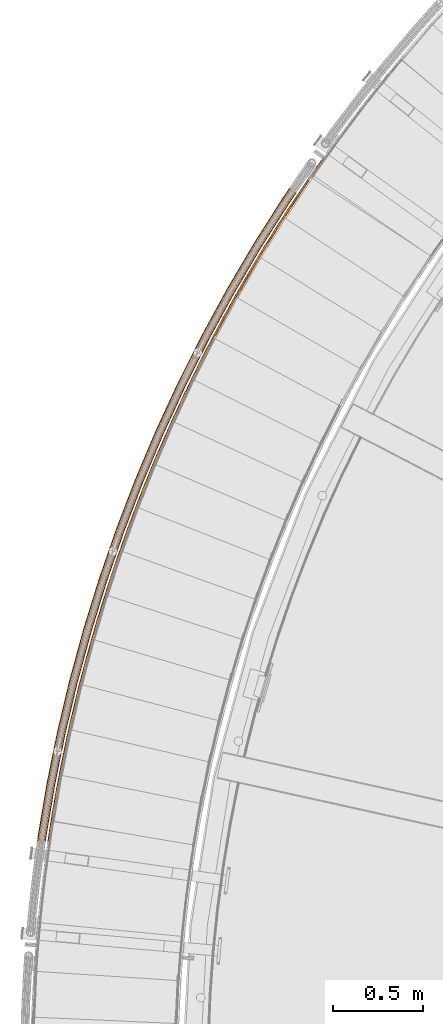
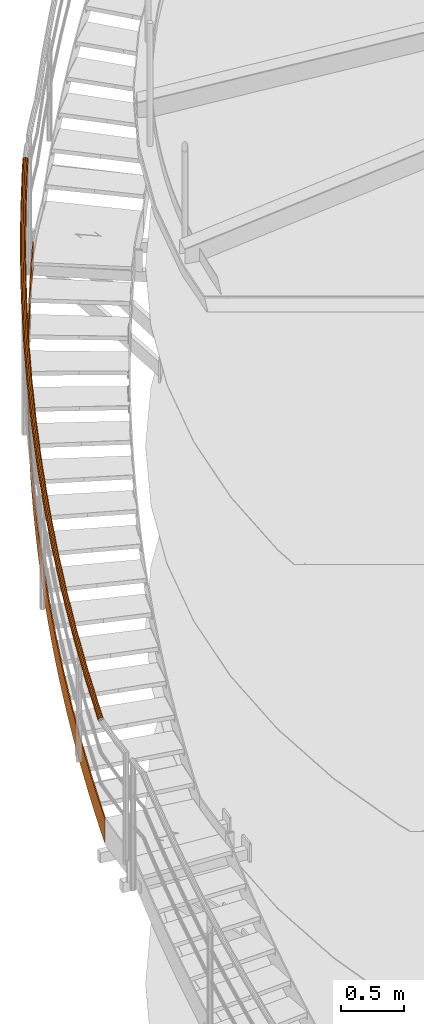
# One storey, part 26 of 126: 2 proxies.
"""IFC2X3 building model written with IfcOpenShell, lengths in millimetres."""

from ifc_helpers import new_model, si_unit, origin, origin_with_axes, place, context, project, spatial, faceted_brep, material, element, save


model = new_model("IFC2X3")

# Units and contexts
context_of_model_1 = context(None, 3, precision=0.1, world=origin())
context_of_model_2 = context(None, 3, precision=0.1, world=origin())
ifc_project = project(units=[si_unit("LENGTHUNIT", "METRE", prefix="MILLI"), si_unit("AREAUNIT", "SQUARE_METRE", prefix="CENTI"), si_unit("VOLUMEUNIT", "CUBIC_METRE", prefix="CENTI"), si_unit("MASSUNIT", "GRAM", prefix="KILO")], contexts=[context_of_model_1, context_of_model_2])

# Site, building, storey
site_placement = place(None, origin_with_axes())
site = spatial("IfcSite", under=ifc_project, at=site_placement, CompositionType="ELEMENT")
building_placement = place(site_placement, origin_with_axes())
building = spatial("IfcBuilding", under=site, at=building_placement, CompositionType="ELEMENT")
storey_placement = place(building_placement, origin_with_axes())
storey = spatial("IfcBuildingStorey", under=building, at=storey_placement, CompositionType="ELEMENT")

# Proxies
ifc_material = material(Name="S235JRG2")
proxy_1_placement = place(storey_placement, origin_with_axes())
element("IfcBuildingElementProxy", 1, at=proxy_1_placement, inside=storey, material=ifc_material, context=context_of_model_2, shape_type="Brep", body=[
    faceted_brep([(-726.5215, 9313.3481, 5409.2555), (-716.6318, 9311.8662, 5409.1818), (-718.1607, 9301.2803, 5402.0481), (-728.1705, 9301.9311, 5401.5657), (-716.6318, 9311.8662, 5649.5856), (-718.1607, 9301.2803, 5642.4497), (-726.5215, 9313.3481, 5649.6209), (-728.1705, 9301.9311, 5641.9335), (-712.1768, 9405.7396, 5471.5751), (-702.3033, 9404.1531, 5471.4807), (-702.3033, 9404.1531, 5711.8948), (-712.1768, 9405.7396, 5711.9301), (-696.8544, 9497.9741, 5533.89), (-686.9983, 9496.2831, 5533.7843), (-686.9983, 9496.2831, 5774.2041), (-696.8544, 9497.9741, 5774.2394), (-680.5562, 9590.0411, 5596.2023), (-670.7185, 9588.2458, 5596.0904), (-670.7185, 9588.2458, 5836.5133), (-680.5562, 9590.0411, 5836.5486), (-663.2839, 9681.9304, 5658.5132), (-653.4658, 9680.031, 5658.398), (-653.4658, 9680.031, 5898.8226), (-663.2839, 9681.9304, 5898.8579), (-645.0395, 9773.6316, 5720.8234), (-635.2421, 9771.6283, 5720.7064), (-635.2421, 9771.6283, 5961.1318), (-645.0395, 9773.6316, 5961.1671), (-625.8251, 9865.1344, 5783.1331), (-616.0494, 9863.0275, 5783.0151), (-616.0494, 9863.0275, 6023.4411), (-625.8251, 9865.1344, 6023.4764), (-605.6427, 9956.4287, 5845.4426), (-595.8899, 9954.2184, 5845.3241), (-595.8899, 9954.2184, 6085.7503), (-605.6427, 9956.4287, 6085.7856), (-584.4946, 10047.504, 5907.752), (-574.7658, 10045.191, 5907.6332), (-574.7658, 10045.191, 6148.0596), (-584.4946, 10047.504, 6148.0949), (-562.3833, 10138.35, 5970.0613), (-552.6795, 10135.934, 5969.9424), (-552.6795, 10135.934, 6210.3688), (-562.3833, 10138.35, 6210.4041), (-539.3112, 10228.958, 6032.3706), (-529.6335, 10226.439, 6032.2516), (-529.6335, 10226.439, 6272.6781), (-539.3112, 10228.958, 6272.7134), (-515.2809, 10319.315, 6094.6799), (-505.6304, 10316.694, 6094.5608), (-505.6304, 10316.694, 6334.9873), (-515.2809, 10319.315, 6335.0226), (-490.295, 10409.413, 6156.9892), (-480.6728, 10406.69, 6156.87), (-480.6728, 10406.69, 6397.2966), (-490.295, 10409.413, 6397.3319), (-464.3564, 10499.242, 6219.2984), (-454.7636, 10496.417, 6219.1793), (-454.7636, 10496.417, 6459.6058), (-464.3564, 10499.242, 6459.6411), (-437.468, 10588.791, 6281.6077), (-427.9057, 10585.864, 6281.4885), (-427.9057, 10585.864, 6521.915), (-437.468, 10588.791, 6521.9504), (-409.6328, 10678.05, 6343.9169), (-400.102, 10675.022, 6343.7978), (-400.102, 10675.022, 6584.2243), (-409.6328, 10678.05, 6584.2596), (-380.854, 10767.009, 6406.2262), (-371.3558, 10763.88, 6406.107), (-371.3558, 10763.88, 6646.5335), (-380.854, 10767.009, 6646.5688), (-351.1347, 10855.658, 6468.5354), (-341.6701, 10852.43, 6468.4163), (-341.6701, 10852.43, 6708.8428), (-351.1347, 10855.658, 6708.8781), (-320.4783, 10943.988, 6530.8447), (-311.0485, 10940.659, 6530.7255), (-311.0485, 10940.659, 6771.152), (-320.4783, 10943.988, 6771.1873), (-288.8882, 11031.988, 6593.1539), (-279.4942, 11028.56, 6593.0347), (-279.4942, 11028.56, 6833.4613), (-288.8882, 11031.988, 6833.4966), (-256.368, 11119.649, 6655.4631), (-247.0108, 11116.121, 6655.344), (-247.0108, 11116.121, 6895.7705), (-256.368, 11119.649, 6895.8058), (-222.9213, 11206.96, 6717.7724), (-213.602, 11203.334, 6717.6532), (-213.602, 11203.334, 6958.0798), (-222.9213, 11206.96, 6958.1151), (-188.5519, 11293.913, 6780.0816), (-179.2715, 11290.188, 6779.9625), (-179.2715, 11290.188, 7020.389), (-188.5519, 11293.913, 7020.4243), (-153.2635, 11380.496, 6842.3909), (-144.0231, 11376.673, 6842.2717), (-144.0231, 11376.673, 7082.6983), (-153.2635, 11380.496, 7082.7336), (-117.0603, 11466.701, 6904.7001), (-107.8609, 11462.781, 6904.581), (-107.8609, 11462.781, 7145.0075), (-117.0603, 11466.701, 7145.0428), (-79.9462, 11552.518, 6967.0094), (-70.7888, 11548.5, 6966.8902), (-70.7888, 11548.5, 7207.3168), (-79.9462, 11552.518, 7207.3521), (-41.9254, 11637.937, 7029.3186), (-32.8111, 11633.822, 7029.1995), (-32.8111, 11633.822, 7269.626), (-41.9254, 11637.937, 7269.6613), (-3.0022, 11722.949, 7091.6279), (6.068, 11718.737, 7091.5087), (6.068, 11718.737, 7331.9353), (-3.0022, 11722.949, 7331.9706), (36.8191, 11807.543, 7153.9371), (45.8442, 11803.236, 7153.818), (45.8442, 11803.236, 7394.2445), (36.8191, 11807.543, 7394.2798), (77.534, 11891.711, 7216.2464), (86.513, 11887.309, 7216.1272), (86.513, 11887.309, 7456.5538), (77.534, 11891.711, 7456.5891), (119.1379, 11975.443, 7278.5556), (128.0698, 11970.946, 7278.4365), (128.0698, 11970.946, 7518.863), (119.1379, 11975.443, 7518.8983), (161.6262, 12058.73, 7340.8649), (170.51, 12054.139, 7340.7457), (170.51, 12054.139, 7581.1723), (161.6262, 12058.73, 7581.2076), (204.9942, 12141.563, 7403.1741), (213.8288, 12136.877, 7403.055), (213.8288, 12136.877, 7643.4815), (204.9942, 12141.563, 7643.5168), (249.2368, 12223.931, 7465.4834), (258.0214, 12219.152, 7465.3642), (258.0214, 12219.152, 7705.7908), (249.2368, 12223.931, 7705.8261), (294.3493, 12305.826, 7527.7926), (303.0827, 12300.955, 7527.6735), (303.0827, 12300.955, 7768.1), (294.3493, 12305.826, 7768.1353), (340.3264, 12387.239, 7590.1019), (349.0078, 12382.276, 7589.9827), (349.0078, 12382.276, 7830.4092), (340.3264, 12387.239, 7830.4446), (387.1632, 12468.161, 7652.4111), (395.7915, 12463.106, 7652.292), (395.7915, 12463.106, 7892.7185), (387.1632, 12468.161, 7892.7538), (434.8542, 12548.582, 7714.7204), (443.4285, 12543.435, 7714.6012), (443.4285, 12543.435, 7955.0277), (434.8542, 12548.582, 7955.063), (483.3942, 12628.493, 7777.0296), (491.9136, 12623.256, 7776.9105), (491.9136, 12623.256, 8017.337), (483.3942, 12628.493, 8017.3723), (532.7778, 12707.886, 7839.3389), (541.2412, 12702.559, 7839.2197), (541.2412, 12702.559, 8079.6462), (532.7778, 12707.886, 8079.6815), (582.9993, 12786.752, 7901.6481), (591.4058, 12781.335, 7901.5289), (591.4058, 12781.335, 8141.9555), (582.9993, 12786.752, 8141.9908), (634.0532, 12865.081, 7963.9573), (642.4018, 12859.576, 7963.8382), (642.4018, 12859.576, 8204.2647), (634.0532, 12865.081, 8204.3), (685.9337, 12942.865, 8026.2666), (694.2236, 12937.272, 8026.1474), (694.2236, 12937.272, 8266.574), (685.9337, 12942.865, 8266.6093), (738.635, 13020.095, 8088.5758), (746.8652, 13014.415, 8088.4567), (746.8652, 13014.415, 8328.8832), (738.635, 13020.095, 8328.9185), (792.1512, 13096.763, 8150.8851), (800.3208, 13090.996, 8150.7659), (800.3208, 13090.996, 8391.1925), (792.1512, 13096.763, 8391.2278), (811.9618, 13124.513, 8173.6072), (820.2017, 13118.845, 8173.5947), (820.2017, 13118.845, 8414.0212), (811.9618, 13124.513, 8413.9499)], [[[0, 1, 2, 3]], [[1, 4, 5, 2]], [[4, 6, 7, 5]], [[0, 3, 7, 6]], [[0, 8, 9, 1]], [[1, 9, 10, 4]], [[4, 10, 11, 6]], [[6, 11, 8, 0]], [[8, 12, 13, 9]], [[9, 13, 14, 10]], [[10, 14, 15, 11]], [[11, 15, 12, 8]], [[12, 16, 17, 13]], [[13, 17, 18, 14]], [[14, 18, 19, 15]], [[15, 19, 16, 12]], [[16, 20, 21, 17]], [[17, 21, 22, 18]], [[18, 22, 23, 19]], [[19, 23, 20, 16]], [[20, 24, 25, 21]], [[21, 25, 26, 22]], [[22, 26, 27, 23]], [[23, 27, 24, 20]], [[24, 28, 29, 25]], [[25, 29, 30, 26]], [[26, 30, 31, 27]], [[27, 31, 28, 24]], [[28, 32, 33, 29]], [[29, 33, 34, 30]], [[30, 34, 35, 31]], [[31, 35, 32, 28]], [[32, 36, 37, 33]], [[33, 37, 38, 34]], [[34, 38, 39, 35]], [[35, 39, 36, 32]], [[36, 40, 41, 37]], [[37, 41, 42, 38]], [[38, 42, 43, 39]], [[39, 43, 40, 36]], [[40, 44, 45, 41]], [[41, 45, 46, 42]], [[42, 46, 47, 43]], [[43, 47, 44, 40]], [[44, 48, 49, 45]], [[45, 49, 50, 46]], [[46, 50, 51, 47]], [[47, 51, 48, 44]], [[48, 52, 53, 49]], [[49, 53, 54, 50]], [[50, 54, 55, 51]], [[51, 55, 52, 48]], [[52, 56, 57, 53]], [[53, 57, 58, 54]], [[54, 58, 59, 55]], [[55, 59, 56, 52]], [[56, 60, 61, 57]], [[57, 61, 62, 58]], [[58, 62, 63, 59]], [[59, 63, 60, 56]], [[60, 64, 65, 61]], [[61, 65, 66, 62]], [[62, 66, 67, 63]], [[63, 67, 64, 60]], [[64, 68, 69, 65]], [[65, 69, 70, 66]], [[66, 70, 71, 67]], [[67, 71, 68, 64]], [[68, 72, 73, 69]], [[69, 73, 74, 70]], [[70, 74, 75, 71]], [[71, 75, 72, 68]], [[72, 76, 77, 73]], [[73, 77, 78, 74]], [[74, 78, 79, 75]], [[75, 79, 76, 72]], [[76, 80, 81, 77]], [[77, 81, 82, 78]], [[78, 82, 83, 79]], [[79, 83, 80, 76]], [[80, 84, 85, 81]], [[81, 85, 86, 82]], [[82, 86, 87, 83]], [[83, 87, 84, 80]], [[84, 88, 89, 85]], [[85, 89, 90, 86]], [[86, 90, 91, 87]], [[87, 91, 88, 84]], [[88, 92, 93, 89]], [[89, 93, 94, 90]], [[90, 94, 95, 91]], [[91, 95, 92, 88]], [[92, 96, 97, 93]], [[93, 97, 98, 94]], [[94, 98, 99, 95]], [[95, 99, 96, 92]], [[96, 100, 101, 97]], [[97, 101, 102, 98]], [[98, 102, 103, 99]], [[99, 103, 100, 96]], [[100, 104, 105, 101]], [[101, 105, 106, 102]], [[102, 106, 107, 103]], [[103, 107, 104, 100]], [[104, 108, 109, 105]], [[105, 109, 110, 106]], [[106, 110, 111, 107]], [[107, 111, 108, 104]], [[108, 112, 113, 109]], [[109, 113, 114, 110]], [[110, 114, 115, 111]], [[111, 115, 112, 108]], [[112, 116, 117, 113]], [[113, 117, 118, 114]], [[114, 118, 119, 115]], [[115, 119, 116, 112]], [[116, 120, 121, 117]], [[117, 121, 122, 118]], [[118, 122, 123, 119]], [[119, 123, 120, 116]], [[120, 124, 125, 121]], [[121, 125, 126, 122]], [[122, 126, 127, 123]], [[123, 127, 124, 120]], [[124, 128, 129, 125]], [[125, 129, 130, 126]], [[126, 130, 131, 127]], [[127, 131, 128, 124]], [[128, 132, 133, 129]], [[129, 133, 134, 130]], [[130, 134, 135, 131]], [[131, 135, 132, 128]], [[132, 136, 137, 133]], [[133, 137, 138, 134]], [[134, 138, 139, 135]], [[135, 139, 136, 132]], [[136, 140, 141, 137]], [[137, 141, 142, 138]], [[138, 142, 143, 139]], [[139, 143, 140, 136]], [[140, 144, 145, 141]], [[141, 145, 146, 142]], [[142, 146, 147, 143]], [[143, 147, 144, 140]], [[144, 148, 149, 145]], [[145, 149, 150, 146]], [[146, 150, 151, 147]], [[147, 151, 148, 144]], [[148, 152, 153, 149]], [[149, 153, 154, 150]], [[150, 154, 155, 151]], [[151, 155, 152, 148]], [[152, 156, 157, 153]], [[153, 157, 158, 154]], [[154, 158, 159, 155]], [[155, 159, 156, 152]], [[156, 160, 161, 157]], [[157, 161, 162, 158]], [[158, 162, 163, 159]], [[159, 163, 160, 156]], [[160, 164, 165, 161]], [[161, 165, 166, 162]], [[162, 166, 167, 163]], [[163, 167, 164, 160]], [[164, 168, 169, 165]], [[165, 169, 170, 166]], [[166, 170, 171, 167]], [[167, 171, 168, 164]], [[168, 172, 173, 169]], [[169, 173, 174, 170]], [[170, 174, 175, 171]], [[171, 175, 172, 168]], [[172, 176, 177, 173]], [[173, 177, 178, 174]], [[174, 178, 179, 175]], [[175, 179, 176, 172]], [[176, 180, 181, 177]], [[177, 181, 182, 178]], [[178, 182, 183, 179]], [[179, 183, 180, 176]], [[180, 184, 185, 181]], [[181, 185, 186, 182]], [[182, 186, 187, 183]], [[180, 183, 187, 184]], [[2, 5, 7, 3]], [[184, 187, 186, 185]]]),
])
proxy_2_placement = place(storey_placement, origin_with_axes())
element("IfcBuildingElementProxy", 2, at=proxy_2_placement, inside=storey, material=ifc_material, Name="HANDLAUF", context=context_of_model_2, shape_type="Brep", body=[
    faceted_brep([(-761.4332, 9316.5433, 6657.9389), (-773.1405, 9320.1123, 6655.389), (-776.2437, 9296.7196, 6638.7572), (-764.3214, 9294.771, 6642.4592), (-781.2205, 9326.4212, 6648.2336), (-784.7017, 9300.1794, 6629.5762), (-783.5082, 9333.7795, 6638.3899), (-787.4291, 9304.2235, 6617.3762), (-779.3906, 9340.2156, 6628.4956), (-783.695, 9307.7683, 6605.4262), (-769.9709, 9344.005, 6621.2018), (-774.5, 9309.8639, 6596.9282), (-757.7732, 9344.1322, 6618.463), (-762.308, 9309.9488, 6594.1592), (-746.0659, 9340.5633, 6621.0128), (-750.3857, 9308.0003, 6597.8612), (-737.9859, 9334.2544, 6628.1683), (-741.9277, 9304.5405, 6607.0422), (-735.6982, 9326.8961, 6638.0119), (-739.2004, 9300.4964, 6619.2422), (-739.8158, 9320.4599, 6647.9062), (-742.9344, 9296.9516, 6631.1922), (-749.2355, 9316.6706, 6655.2), (-752.1294, 9294.856, 6639.6902), (-761.2437, 9317.9713, 6655.8956), (-750.3088, 9318.0854, 6653.4403), (-753.2873, 9295.6328, 6637.4769), (-764.2172, 9295.5566, 6639.9592), (-741.8642, 9321.4825, 6646.9015), (-745.0442, 9297.5115, 6629.8586), (-738.1728, 9327.2523, 6638.0315), (-741.6967, 9300.6893, 6619.1456), (-740.2237, 9333.8489, 6629.2068), (-744.1417, 9304.3147, 6608.2086), (-747.4673, 9339.5047, 6622.7922), (-751.7241, 9307.4164, 6599.978), (-757.9627, 9342.7042, 6620.5062), (-762.4122, 9309.1632, 6596.6592), (-768.8976, 9342.5902, 6622.9616), (-773.3421, 9309.0871, 6599.1415), (-777.3422, 9339.1931, 6629.5003), (-781.5852, 9307.2084, 6606.7598), (-781.0336, 9333.4232, 6638.3704), (-784.9328, 9304.0306, 6617.4727), (-778.9827, 9326.8266, 6647.195), (-782.4877, 9300.4051, 6628.4098), (-771.7391, 9321.1708, 6653.6097), (-774.9053, 9297.3034, 6636.6404), (-713.0048, 9607.1508, 6865.5856), (-724.5871, 9611.1069, 6863.0357), (-732.4528, 9617.6809, 6855.8801), (-734.4944, 9625.1112, 6846.0363), (-730.1651, 9631.4069, 6836.1421), (-720.6248, 9634.881, 6828.8485), (-708.4301, 9634.6028, 6826.1097), (-696.8482, 9630.6469, 6828.6595), (-688.9824, 9624.0731, 6835.8148), (-686.9404, 9616.6429, 6845.6583), (-691.2695, 9610.3471, 6855.5527), (-700.8097, 9606.8727, 6862.8467), (-712.768, 9608.5717, 6863.5424), (-701.8354, 9608.3224, 6861.0869), (-693.2827, 9611.4371, 6854.5481), (-689.4018, 9617.0812, 6845.678), (-691.2324, 9623.7422, 6836.8534), (-698.2839, 9629.6355, 6830.4388), (-708.6669, 9633.1819, 6828.153), (-719.5992, 9633.4313, 6830.6083), (-728.1519, 9630.3168, 6837.1468), (-732.033, 9624.6729, 6846.0168), (-730.2027, 9618.0118, 6854.8415), (-723.1513, 9612.1183, 6861.2564), (-654.9456, 9895.9884, 7073.2324), (-666.39, 9900.3272, 7070.6824), (-674.0329, 9907.159, 7063.5268), (-675.8265, 9914.653, 7053.6831), (-671.2903, 9920.8013, 7043.7888), (-661.6399, 9923.9565, 7036.4952), (-649.4611, 9923.2732, 7033.7565), (-638.0171, 9918.9346, 7036.3063), (-630.3741, 9912.103, 7043.4615), (-628.5801, 9904.609, 7053.3051), (-633.116, 9898.4605, 7063.1995), (-642.7664, 9895.3051, 7070.4934), (-654.6617, 9897.4006, 7071.1891), (-643.7434, 9896.7881, 7068.7337), (-635.0919, 9899.6169, 7062.1948), (-631.0256, 9905.1289, 7053.3247), (-632.6338, 9911.8471, 7044.5001), (-639.4856, 9917.9714, 7038.0856), (-649.745, 9921.8609, 7035.7997), (-660.663, 9922.4735, 7038.255), (-669.3144, 9919.6449, 7044.7936), (-673.381, 9914.1331, 7053.6636), (-671.7731, 9907.4148, 7062.4883), (-664.9214, 9901.2903, 7068.9031), (-587.3196, 10182.737, 7280.8791), (-598.6135, 10187.454, 7278.3291), (-606.0251, 10194.536, 7271.1736), (-607.5687, 10202.085, 7261.3298), (-602.8306, 10208.079, 7251.4356), (-593.0807, 10210.912, 7244.142), (-580.9314, 10209.824, 7241.4032), (-569.6379, 10205.108, 7243.953), (-562.2261, 10198.026, 7251.1083), (-560.6822, 10190.477, 7260.9518), (-565.4199, 10184.482, 7270.8462), (-575.1699, 10181.649, 7278.1402), (-586.989, 10184.139, 7278.8359), (-576.097, 10183.164, 7276.3804), (-567.3563, 10185.704, 7269.8416), (-563.1091, 10191.077, 7260.9715), (-564.4931, 10197.845, 7252.1469), (-571.1376, 10204.194, 7245.7323), (-581.262, 10208.422, 7243.4465), (-592.1537, 10209.397, 7245.9017), (-600.8943, 10206.858, 7252.4403), (-605.1418, 10201.484, 7261.3103), (-603.7581, 10194.716, 7270.135), (-597.1137, 10188.368, 7276.5499), (-510.2016, 10467.08, 7488.5259), (-521.3324, 10472.169, 7485.9759), (-528.5046, 10479.494, 7478.8203), (-529.7964, 10487.09, 7468.9765), (-524.8618, 10492.924, 7459.0823), (-515.0231, 10495.431, 7451.7887), (-502.9166, 10493.94, 7449.0499), (-491.7861, 10488.851, 7451.5998), (-484.6139, 10481.527, 7458.755), (-483.3217, 10473.93, 7468.5986), (-488.256, 10468.096, 7478.493), (-498.0947, 10465.589, 7485.7869), (-509.8245, 10468.47, 7486.4826), (-498.9709, 10467.134, 7484.0272), (-490.1507, 10469.381, 7477.4883), (-485.7272, 10474.611, 7468.6182), (-486.8856, 10481.421, 7459.7936), (-493.3154, 10487.987, 7453.3791), (-503.2937, 10492.55, 7451.0932), (-514.147, 10493.886, 7453.5485), (-522.9671, 10491.638, 7460.0871), (-527.3909, 10486.409, 7468.9571), (-526.2328, 10479.599, 7477.7818), (-519.8031, 10473.033, 7484.1966), (-423.6766, 10748.703, 7696.1726), (-434.6322, 10754.159, 7693.6226), (-441.557, 10761.718, 7686.467), (-442.5957, 10769.353, 7676.6233), (-437.4699, 10775.019, 7666.7291), (-427.5534, 10777.198, 7659.4355), (-415.5031, 10775.306, 7656.6967), (-404.5479, 10769.85, 7659.2465), (-397.623, 10762.291, 7666.4018), (-396.584, 10754.656, 7676.2453), (-401.7094, 10748.989, 7686.1397), (-411.626, 10746.81, 7693.4336), (-423.2536, 10750.08, 7694.1293), (-412.4504, 10748.383, 7691.6739), (-403.5604, 10750.337, 7685.1351), (-398.9655, 10755.416, 7676.265), (-399.897, 10762.261, 7667.4404), (-406.105, 10769.037, 7661.0258), (-415.9262, 10773.929, 7658.74), (-426.729, 10775.625, 7661.1952), (-435.619, 10773.672, 7667.7338), (-440.2141, 10768.593, 7676.6038), (-439.283, 10761.747, 7685.4285), (-433.075, 10754.971, 7691.8434), (-327.8404, 11027.295, 7903.8194), (-338.6086, 11033.112, 7901.2694), (-345.2784, 11040.897, 7894.1138), (-346.0627, 11048.563, 7884.27), (-340.7515, 11054.055, 7874.3758), (-330.768, 11055.903, 7867.0822), (-318.7873, 11053.612, 7864.3434), (-308.0195, 11047.794, 7866.8933), (-301.3496, 11040.01, 7874.0485), (-300.5649, 11032.344, 7883.8921), (-305.8758, 11026.851, 7893.7864), (-315.8593, 11025.003, 7901.0804), (-327.3719, 11028.657, 7901.7761), (-316.631, 11026.602, 7899.3207), (-307.681, 11028.259, 7892.7818), (-302.9199, 11033.183, 7883.9117), (-303.6233, 11040.056, 7875.0871), (-309.6027, 11047.034, 7868.6726), (-319.2559, 11052.249, 7866.3867), (-329.9964, 11054.304, 7868.842), (-338.9464, 11052.647, 7875.3806), (-343.7078, 11047.723, 7884.2505), (-343.0047, 11040.851, 7893.0753), (-337.0253, 11033.872, 7899.4901), (-222.7988, 11302.548, 8111.4661), (-233.3677, 11308.72, 8108.9161), (-239.7752, 11316.722, 8101.7605), (-240.3043, 11324.409, 8091.9168), (-234.8135, 11329.723, 8082.0226), (-224.7741, 11331.238, 8074.729), (-212.8761, 11328.549, 8071.9902), (-202.3075, 11322.377, 8074.54), (-195.9, 11314.375, 8081.6952), (-195.3705, 11306.688, 8091.5388), (-200.861, 11301.374, 8101.4332), (-210.9005, 11299.859, 8108.7271), (-222.2852, 11303.893, 8109.4228), (-211.6186, 11301.483, 8106.9674), (-202.6185, 11302.842, 8100.4286), (-197.6963, 11307.605, 8091.5584), (-198.171, 11314.497, 8082.7339), (-203.9152, 11321.67, 8076.3193), (-213.3897, 11327.203, 8074.0335), (-224.056, 11329.614, 8076.4887), (-233.0561, 11328.255, 8083.0273), (-237.9785, 11323.492, 8091.8973), (-237.5042, 11316.6, 8100.722), (-231.76, 11309.427, 8107.1368), (-108.6678, 11574.158, 8319.1129), (-119.0258, 11580.678, 8316.5629), (-125.1637, 11588.888, 8309.4073), (-125.4371, 11596.589, 8299.5635), (-119.7728, 11601.717, 8289.6693), (-109.6886, 11602.898, 8282.3757), (-97.8865, 11599.815, 8279.6369), (-87.5289, 11593.296, 8282.1867), (-81.3908, 11585.085, 8289.342), (-81.1171, 11577.384, 8299.1856), (-86.7812, 11572.256, 8309.0799), (-96.8654, 11571.075, 8316.3739), (-108.1098, 11575.486, 8317.0696), (-97.5292, 11572.722, 8314.6142), (-88.4889, 11573.781, 8308.0753), (-83.4111, 11578.378, 8299.2052), (-83.6565, 11585.282, 8290.3806), (-89.1591, 11592.642, 8283.9661), (-98.4446, 11598.487, 8281.6802), (-109.0249, 11601.251, 8284.1355), (-118.0652, 11600.192, 8290.6741), (-123.1431, 11595.595, 8299.544), (-122.898, 11588.692, 8308.3688), (-117.3955, 11581.331, 8314.7836), (14.4264, 11841.825, 8526.7596), (4.2909, 11848.686, 8524.2096), (-1.5708, 11857.096, 8517.054), (-1.5881, 11864.802, 8507.2103), (4.2435, 11869.738, 8497.3161), (14.3614, 11870.583, 8490.0225), (26.0544, 11867.11, 8487.2837), (36.1897, 11860.25, 8489.8335), (42.0515, 11851.84, 8496.9887), (42.0692, 11844.134, 8506.8323), (36.2378, 11839.197, 8516.7267), (26.1199, 11838.352, 8524.0206), (15.0283, 11843.134, 8524.7163), (25.5112, 11840.02, 8522.2609), (34.5817, 11840.778, 8515.7221), (39.8095, 11845.204, 8506.8519), (39.7936, 11852.112, 8498.0274), (34.5386, 11859.651, 8491.6128), (25.4526, 11865.802, 8489.3269), (14.97, 11868.915, 8491.7822), (5.8995, 11868.157, 8498.3208), (0.6716, 11863.732, 8507.1908), (0.6871, 11856.824, 8516.0155), (5.942, 11849.285, 8522.4303), (146.348, 12105.254, 8734.4063), (136.4461, 12112.448, 8731.8564), (130.8671, 12121.048, 8724.7008), (131.1059, 12128.75, 8714.857), (137.0983, 12133.49, 8704.9628), (147.2387, 12133.998, 8697.6692), (158.8099, 12130.139, 8694.9304), (168.7115, 12122.945, 8697.4802), (174.2906, 12114.345, 8704.6355), (174.0522, 12106.643, 8714.4791), (168.06, 12101.903, 8724.3734), (157.9195, 12101.394, 8731.6674), (146.993, 12106.542, 8732.3631), (157.3667, 12103.082, 8729.9077), (166.4574, 12103.538, 8723.3688), (171.8293, 12107.787, 8714.4987), (172.043, 12114.692, 8705.6741), (167.0415, 12122.402, 8699.2596), (158.1648, 12128.851, 8696.9737), (147.7915, 12132.311, 8699.429), (138.7009, 12131.855, 8705.9676), (133.3287, 12127.606, 8714.8375), (133.1147, 12120.701, 8723.6623), (138.1161, 12112.991, 8730.0771), (286.9511, 12364.153, 8942.0531), (277.2937, 12371.672, 8939.5031), (272.0036, 12380.453, 8932.3475), (272.4982, 12388.143, 8922.5038), (278.6449, 12392.681, 8912.6096), (288.7966, 12392.852, 8905.316), (300.2331, 12388.61, 8902.5772), (309.8902, 12381.091, 8905.127), (315.1805, 12372.311, 8912.2822), (314.6862, 12364.621, 8922.1258), (308.5398, 12360.082, 8932.0202), (298.388, 12359.911, 8939.3141), (287.6386, 12365.419, 8940.0098), (297.8915, 12361.616, 8937.5544), (306.9924, 12361.77, 8931.0155), (312.5025, 12365.838, 8922.1454), (312.9456, 12372.732, 8913.3209), (308.2031, 12380.604, 8906.9063), (299.5456, 12387.344, 8904.6204), (289.293, 12391.147, 8907.0757), (280.1922, 12390.994, 8913.6143), (274.6819, 12386.925, 8922.4843), (274.2385, 12380.031, 8931.309), (278.9809, 12372.16, 8937.7238), (436.0805, 12618.237, 9149.6998), (426.6783, 12626.072, 9147.1499), (421.6829, 12635.024, 9139.9943), (422.4328, 12642.693, 9130.1505), (428.727, 12647.025, 9120.2563), (438.8787, 12646.858, 9112.9627), (450.1679, 12642.238, 9110.2239), (459.5698, 12634.403, 9112.7737), (464.5653, 12625.452, 9119.929), (463.8158, 12617.782, 9129.7725), (457.5219, 12613.451, 9139.6669), (447.3701, 12613.617, 9146.9609), (436.8097, 12619.479, 9147.6566), (446.9305, 12615.337, 9145.2011), (456.0315, 12615.188, 9138.6623), (461.6738, 12619.072, 9129.7922), (462.3458, 12625.947, 9120.9676), (457.8674, 12633.972, 9114.553), (449.4387, 12640.996, 9112.2672), (439.3182, 12645.138, 9114.7225), (430.2173, 12645.287, 9121.261), (424.5748, 12641.404, 9130.131), (423.9025, 12634.529, 9138.9557), (428.3808, 12626.504, 9145.3706), (593.5714, 12867.224, 9357.3466), (584.4348, 12875.368, 9354.7966), (579.7396, 12884.481, 9347.641), (580.744, 12892.12, 9337.7973), (587.1786, 12896.241, 9327.9031), (597.3192, 12895.737, 9320.6095), (608.4486, 12890.744, 9317.8707), (617.585, 12882.601, 9320.4205), (622.2802, 12873.488, 9327.5757), (621.2763, 12865.848, 9337.4193), (614.8419, 12861.728, 9347.3137), (604.7012, 12862.231, 9354.6076), (594.3414, 12868.441, 9355.3033), (604.3191, 12863.966, 9352.8479), (613.41, 12863.514, 9346.309), (619.1783, 12867.208, 9337.4389), (620.0784, 12874.057, 9328.6144), (615.8692, 12882.226, 9322.1998), (607.6786, 12889.527, 9319.9139), (597.7012, 12894.003, 9322.3692), (588.6104, 12894.454, 9328.9078), (582.8419, 12890.761, 9337.7778), (581.9416, 12883.912, 9346.6025), (586.1506, 12875.742, 9353.0173), (638.7269, 12933.621, 9413.9405), (629.3682, 12941.41, 9411.0187), (623.5934, 12948.857, 9402.4114), (622.9469, 12953.97, 9390.4256), (627.6004, 12955.38, 9378.27), (636.3088, 12952.71, 9369.1984), (646.7417, 12946.673, 9365.6408), (656.1049, 12938.884, 9368.5533), (661.8879, 12931.432, 9377.159), (662.5382, 12926.314, 9389.1525), (657.8801, 12924.903, 9401.3173), (649.1634, 12927.579, 9410.3906), (639.1433, 12934.296, 9411.4405), (648.4993, 12928.879, 9408.2577), (656.3132, 12926.481, 9400.1238), (660.4889, 12927.745, 9389.2186), (659.9061, 12932.333, 9378.4671), (654.7221, 12939.014, 9370.7522), (646.3284, 12945.996, 9368.1407), (636.9754, 12951.408, 9371.3297), (629.1681, 12953.802, 9379.4623), (624.9961, 12952.538, 9390.36), (625.5759, 12947.955, 9401.1054), (630.7532, 12941.278, 9408.8216)], [[[0, 1, 2, 3]], [[1, 4, 5, 2]], [[4, 6, 7, 5]], [[6, 8, 9, 7]], [[8, 10, 11, 9]], [[10, 12, 13, 11]], [[12, 14, 15, 13]], [[14, 16, 17, 15]], [[16, 18, 19, 17]], [[18, 20, 21, 19]], [[20, 22, 23, 21]], [[0, 3, 23, 22]], [[24, 25, 26, 27]], [[25, 28, 29, 26]], [[28, 30, 31, 29]], [[30, 32, 33, 31]], [[32, 34, 35, 33]], [[34, 36, 37, 35]], [[36, 38, 39, 37]], [[38, 40, 41, 39]], [[40, 42, 43, 41]], [[42, 44, 45, 43]], [[44, 46, 47, 45]], [[24, 27, 47, 46]], [[0, 48, 49, 1]], [[1, 49, 50, 4]], [[4, 50, 51, 6]], [[6, 51, 52, 8]], [[8, 52, 53, 10]], [[10, 53, 54, 12]], [[12, 54, 55, 14]], [[14, 55, 56, 16]], [[16, 56, 57, 18]], [[18, 57, 58, 20]], [[20, 58, 59, 22]], [[22, 59, 48, 0]], [[24, 60, 61, 25]], [[25, 61, 62, 28]], [[28, 62, 63, 30]], [[30, 63, 64, 32]], [[32, 64, 65, 34]], [[34, 65, 66, 36]], [[36, 66, 67, 38]], [[38, 67, 68, 40]], [[40, 68, 69, 42]], [[42, 69, 70, 44]], [[44, 70, 71, 46]], [[46, 71, 60, 24]], [[48, 72, 73, 49]], [[49, 73, 74, 50]], [[50, 74, 75, 51]], [[51, 75, 76, 52]], [[52, 76, 77, 53]], [[53, 77, 78, 54]], [[54, 78, 79, 55]], [[55, 79, 80, 56]], [[56, 80, 81, 57]], [[57, 81, 82, 58]], [[58, 82, 83, 59]], [[59, 83, 72, 48]], [[60, 84, 85, 61]], [[61, 85, 86, 62]], [[62, 86, 87, 63]], [[63, 87, 88, 64]], [[64, 88, 89, 65]], [[65, 89, 90, 66]], [[66, 90, 91, 67]], [[67, 91, 92, 68]], [[68, 92, 93, 69]], [[69, 93, 94, 70]], [[70, 94, 95, 71]], [[71, 95, 84, 60]], [[72, 96, 97, 73]], [[73, 97, 98, 74]], [[74, 98, 99, 75]], [[75, 99, 100, 76]], [[76, 100, 101, 77]], [[77, 101, 102, 78]], [[78, 102, 103, 79]], [[79, 103, 104, 80]], [[80, 104, 105, 81]], [[81, 105, 106, 82]], [[82, 106, 107, 83]], [[83, 107, 96, 72]], [[84, 108, 109, 85]], [[85, 109, 110, 86]], [[86, 110, 111, 87]], [[87, 111, 112, 88]], [[88, 112, 113, 89]], [[89, 113, 114, 90]], [[90, 114, 115, 91]], [[91, 115, 116, 92]], [[92, 116, 117, 93]], [[93, 117, 118, 94]], [[94, 118, 119, 95]], [[95, 119, 108, 84]], [[96, 120, 121, 97]], [[97, 121, 122, 98]], [[98, 122, 123, 99]], [[99, 123, 124, 100]], [[100, 124, 125, 101]], [[101, 125, 126, 102]], [[102, 126, 127, 103]], [[103, 127, 128, 104]], [[104, 128, 129, 105]], [[105, 129, 130, 106]], [[106, 130, 131, 107]], [[107, 131, 120, 96]], [[108, 132, 133, 109]], [[109, 133, 134, 110]], [[110, 134, 135, 111]], [[111, 135, 136, 112]], [[112, 136, 137, 113]], [[113, 137, 138, 114]], [[114, 138, 139, 115]], [[115, 139, 140, 116]], [[116, 140, 141, 117]], [[117, 141, 142, 118]], [[118, 142, 143, 119]], [[119, 143, 132, 108]], [[120, 144, 145, 121]], [[121, 145, 146, 122]], [[122, 146, 147, 123]], [[123, 147, 148, 124]], [[124, 148, 149, 125]], [[125, 149, 150, 126]], [[126, 150, 151, 127]], [[127, 151, 152, 128]], [[128, 152, 153, 129]], [[129, 153, 154, 130]], [[130, 154, 155, 131]], [[131, 155, 144, 120]], [[132, 156, 157, 133]], [[133, 157, 158, 134]], [[134, 158, 159, 135]], [[135, 159, 160, 136]], [[136, 160, 161, 137]], [[137, 161, 162, 138]], [[138, 162, 163, 139]], [[139, 163, 164, 140]], [[140, 164, 165, 141]], [[141, 165, 166, 142]], [[142, 166, 167, 143]], [[143, 167, 156, 132]], [[144, 168, 169, 145]], [[145, 169, 170, 146]], [[146, 170, 171, 147]], [[147, 171, 172, 148]], [[148, 172, 173, 149]], [[149, 173, 174, 150]], [[150, 174, 175, 151]], [[151, 175, 176, 152]], [[152, 176, 177, 153]], [[153, 177, 178, 154]], [[154, 178, 179, 155]], [[155, 179, 168, 144]], [[156, 180, 181, 157]], [[157, 181, 182, 158]], [[158, 182, 183, 159]], [[159, 183, 184, 160]], [[160, 184, 185, 161]], [[161, 185, 186, 162]], [[162, 186, 187, 163]], [[163, 187, 188, 164]], [[164, 188, 189, 165]], [[165, 189, 190, 166]], [[166, 190, 191, 167]], [[167, 191, 180, 156]], [[168, 192, 193, 169]], [[169, 193, 194, 170]], [[170, 194, 195, 171]], [[171, 195, 196, 172]], [[172, 196, 197, 173]], [[173, 197, 198, 174]], [[174, 198, 199, 175]], [[175, 199, 200, 176]], [[176, 200, 201, 177]], [[177, 201, 202, 178]], [[178, 202, 203, 179]], [[179, 203, 192, 168]], [[180, 204, 205, 181]], [[181, 205, 206, 182]], [[182, 206, 207, 183]], [[183, 207, 208, 184]], [[184, 208, 209, 185]], [[185, 209, 210, 186]], [[186, 210, 211, 187]], [[187, 211, 212, 188]], [[188, 212, 213, 189]], [[189, 213, 214, 190]], [[190, 214, 215, 191]], [[191, 215, 204, 180]], [[192, 216, 217, 193]], [[193, 217, 218, 194]], [[194, 218, 219, 195]], [[195, 219, 220, 196]], [[196, 220, 221, 197]], [[197, 221, 222, 198]], [[198, 222, 223, 199]], [[199, 223, 224, 200]], [[200, 224, 225, 201]], [[201, 225, 226, 202]], [[202, 226, 227, 203]], [[203, 227, 216, 192]], [[204, 228, 229, 205]], [[205, 229, 230, 206]], [[206, 230, 231, 207]], [[207, 231, 232, 208]], [[208, 232, 233, 209]], [[209, 233, 234, 210]], [[210, 234, 235, 211]], [[211, 235, 236, 212]], [[212, 236, 237, 213]], [[213, 237, 238, 214]], [[214, 238, 239, 215]], [[215, 239, 228, 204]], [[216, 240, 241, 217]], [[217, 241, 242, 218]], [[218, 242, 243, 219]], [[219, 243, 244, 220]], [[220, 244, 245, 221]], [[221, 245, 246, 222]], [[222, 246, 247, 223]], [[223, 247, 248, 224]], [[224, 248, 249, 225]], [[225, 249, 250, 226]], [[226, 250, 251, 227]], [[227, 251, 240, 216]], [[228, 252, 253, 229]], [[229, 253, 254, 230]], [[230, 254, 255, 231]], [[231, 255, 256, 232]], [[232, 256, 257, 233]], [[233, 257, 258, 234]], [[234, 258, 259, 235]], [[235, 259, 260, 236]], [[236, 260, 261, 237]], [[237, 261, 262, 238]], [[238, 262, 263, 239]], [[239, 263, 252, 228]], [[240, 264, 265, 241]], [[241, 265, 266, 242]], [[242, 266, 267, 243]], [[243, 267, 268, 244]], [[244, 268, 269, 245]], [[245, 269, 270, 246]], [[246, 270, 271, 247]], [[247, 271, 272, 248]], [[248, 272, 273, 249]], [[249, 273, 274, 250]], [[250, 274, 275, 251]], [[251, 275, 264, 240]], [[252, 276, 277, 253]], [[253, 277, 278, 254]], [[254, 278, 279, 255]], [[255, 279, 280, 256]], [[256, 280, 281, 257]], [[257, 281, 282, 258]], [[258, 282, 283, 259]], [[259, 283, 284, 260]], [[260, 284, 285, 261]], [[261, 285, 286, 262]], [[262, 286, 287, 263]], [[263, 287, 276, 252]], [[264, 288, 289, 265]], [[265, 289, 290, 266]], [[266, 290, 291, 267]], [[267, 291, 292, 268]], [[268, 292, 293, 269]], [[269, 293, 294, 270]], [[270, 294, 295, 271]], [[271, 295, 296, 272]], [[272, 296, 297, 273]], [[273, 297, 298, 274]], [[274, 298, 299, 275]], [[275, 299, 288, 264]], [[276, 300, 301, 277]], [[277, 301, 302, 278]], [[278, 302, 303, 279]], [[279, 303, 304, 280]], [[280, 304, 305, 281]], [[281, 305, 306, 282]], [[282, 306, 307, 283]], [[283, 307, 308, 284]], [[284, 308, 309, 285]], [[285, 309, 310, 286]], [[286, 310, 311, 287]], [[287, 311, 300, 276]], [[288, 312, 313, 289]], [[289, 313, 314, 290]], [[290, 314, 315, 291]], [[291, 315, 316, 292]], [[292, 316, 317, 293]], [[293, 317, 318, 294]], [[294, 318, 319, 295]], [[295, 319, 320, 296]], [[296, 320, 321, 297]], [[297, 321, 322, 298]], [[298, 322, 323, 299]], [[299, 323, 312, 288]], [[300, 324, 325, 301]], [[301, 325, 326, 302]], [[302, 326, 327, 303]], [[303, 327, 328, 304]], [[304, 328, 329, 305]], [[305, 329, 330, 306]], [[306, 330, 331, 307]], [[307, 331, 332, 308]], [[308, 332, 333, 309]], [[309, 333, 334, 310]], [[310, 334, 335, 311]], [[311, 335, 324, 300]], [[312, 336, 337, 313]], [[313, 337, 338, 314]], [[314, 338, 339, 315]], [[315, 339, 340, 316]], [[316, 340, 341, 317]], [[317, 341, 342, 318]], [[318, 342, 343, 319]], [[319, 343, 344, 320]], [[320, 344, 345, 321]], [[321, 345, 346, 322]], [[322, 346, 347, 323]], [[323, 347, 336, 312]], [[324, 348, 349, 325]], [[325, 349, 350, 326]], [[326, 350, 351, 327]], [[327, 351, 352, 328]], [[328, 352, 353, 329]], [[329, 353, 354, 330]], [[330, 354, 355, 331]], [[331, 355, 356, 332]], [[332, 356, 357, 333]], [[333, 357, 358, 334]], [[334, 358, 359, 335]], [[335, 359, 348, 324]], [[336, 360, 361, 337]], [[337, 361, 362, 338]], [[338, 362, 363, 339]], [[339, 363, 364, 340]], [[340, 364, 365, 341]], [[341, 365, 366, 342]], [[342, 366, 367, 343]], [[343, 367, 368, 344]], [[344, 368, 369, 345]], [[345, 369, 370, 346]], [[346, 370, 371, 347]], [[336, 347, 371, 360]], [[348, 372, 373, 349]], [[349, 373, 374, 350]], [[350, 374, 375, 351]], [[351, 375, 376, 352]], [[352, 376, 377, 353]], [[353, 377, 378, 354]], [[354, 378, 379, 355]], [[355, 379, 380, 356]], [[356, 380, 381, 357]], [[357, 381, 382, 358]], [[358, 382, 383, 359]], [[348, 359, 383, 372]], [[7, 9, 11, 13, 15, 17, 19, 21, 23, 3, 2, 5], [26, 29, 31, 33, 35, 37, 39, 41, 43, 45, 47, 27]], [[360, 371, 370, 369, 368, 367, 366, 365, 364, 363, 362, 361], [372, 383, 382, 381, 380, 379, 378, 377, 376, 375, 374, 373]]]),
])

save(model, "model.ifc")
